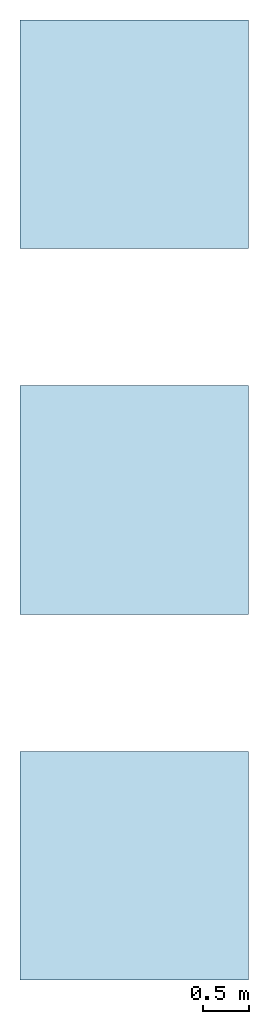
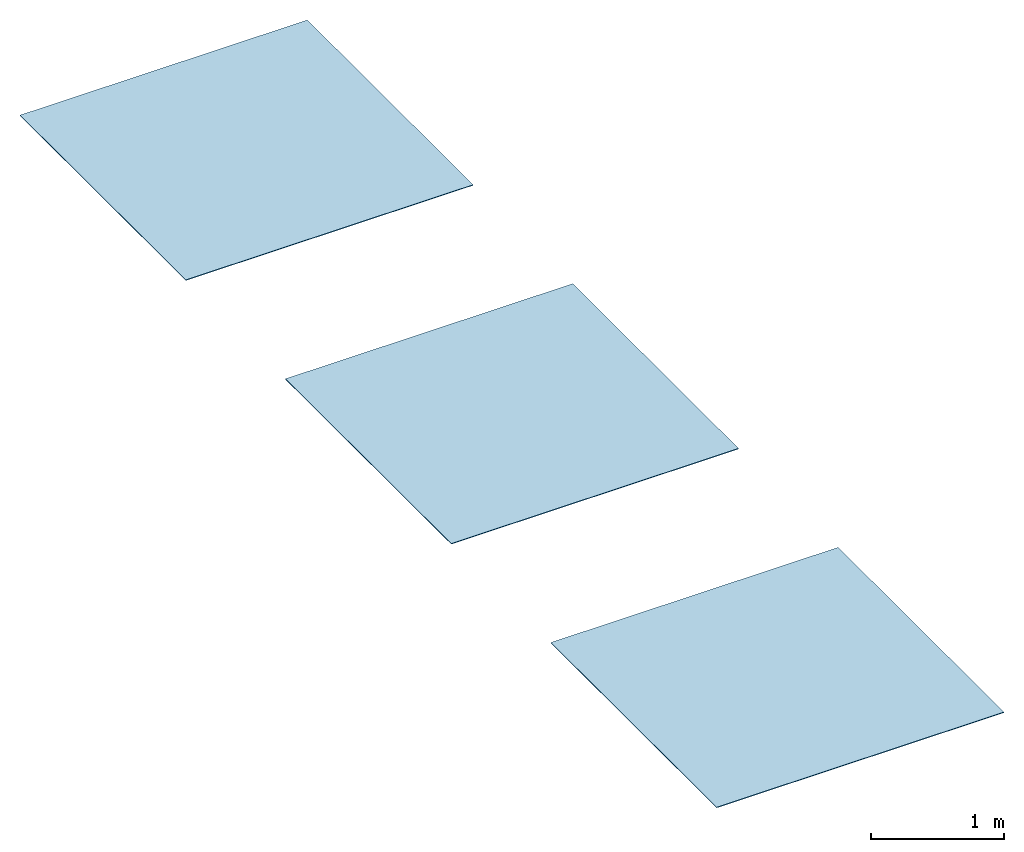
# One storey: 3 slabs, 3 elements without a shape of their own.
"""IFC2X3 building model written with IfcOpenShell, lengths in millimetres."""

from ifc_helpers import new_model, entity, si_unit, converted_unit, derived_unit, direction, frame, frame_2d, origin, place, context, subcontext, project, spatial, rectangle, extrude, material, layer, layer_set, element, aggregate, save


model = new_model("IFC2X3")

# Units and contexts
model_context = context("Model", 3, precision=0.01, world=origin(), true_north=direction((6.12303176911189e-17, 1.0)))
body_context = subcontext(model_context, "Body", "Model", "MODEL_VIEW")
ifc_project = project(units=[si_unit("LENGTHUNIT", "METRE", prefix="MILLI"), si_unit("AREAUNIT", "SQUARE_METRE"), si_unit("VOLUMEUNIT", "CUBIC_METRE"), converted_unit("PLANEANGLEUNIT", "DEGREE", entity("IfcRatioMeasure", 0.0174532925199433), si_unit("PLANEANGLEUNIT", "RADIAN"), dimensions=[0, 0, 0, 0, 0, 0, 0]), si_unit("MASSUNIT", "GRAM", prefix="KILO"), derived_unit("MASSDENSITYUNIT", [(si_unit("MASSUNIT", "GRAM", prefix="KILO"), 1), (si_unit("LENGTHUNIT", "METRE"), -3)]), si_unit("TIMEUNIT", "SECOND"), si_unit("FREQUENCYUNIT", "HERTZ"), si_unit("THERMODYNAMICTEMPERATUREUNIT", "DEGREE_CELSIUS"), derived_unit("THERMALTRANSMITTANCEUNIT", [(si_unit("MASSUNIT", "GRAM", prefix="KILO"), 1), (si_unit("THERMODYNAMICTEMPERATUREUNIT", "KELVIN"), -1), (si_unit("TIMEUNIT", "SECOND"), -3)]), derived_unit("VOLUMETRICFLOWRATEUNIT", [(si_unit("LENGTHUNIT", "METRE"), 3), (si_unit("TIMEUNIT", "SECOND"), -1)]), si_unit("ELECTRICCURRENTUNIT", "AMPERE"), si_unit("ELECTRICVOLTAGEUNIT", "VOLT"), si_unit("POWERUNIT", "WATT"), si_unit("FORCEUNIT", "NEWTON", prefix="KILO"), si_unit("ILLUMINANCEUNIT", "LUX"), si_unit("LUMINOUSFLUXUNIT", "LUMEN"), si_unit("LUMINOUSINTENSITYUNIT", "CANDELA"), derived_unit("USERDEFINED", [(si_unit("MASSUNIT", "GRAM", prefix="KILO"), -1), (si_unit("LENGTHUNIT", "METRE"), -2), (si_unit("TIMEUNIT", "SECOND"), 3), (si_unit("LUMINOUSFLUXUNIT", "LUMEN"), 1)]), derived_unit("LINEARVELOCITYUNIT", [(si_unit("LENGTHUNIT", "METRE"), 1), (si_unit("TIMEUNIT", "SECOND"), -1)]), si_unit("PRESSUREUNIT", "PASCAL"), derived_unit("USERDEFINED", [(si_unit("LENGTHUNIT", "METRE"), -2), (si_unit("MASSUNIT", "GRAM", prefix="KILO"), 1), (si_unit("TIMEUNIT", "SECOND"), -2)])], contexts=[model_context])

# Site, building, storey
site_placement = place(None, origin())
site = spatial("IfcSite", under=ifc_project, at=site_placement, CompositionType="ELEMENT")
building_placement = place(site_placement, origin())
building = spatial("IfcBuilding", under=site, at=building_placement, CompositionType="ELEMENT")
storey_placement = place(building_placement, origin())
storey = spatial("IfcBuildingStorey", under=building, at=storey_placement, Name="Level 0", CompositionType="ELEMENT", Elevation=0.0)

# Roof, slab
roof_1_placement = place(storey_placement, origin())
roof_1 = element("IfcRoof", 1, at=roof_1_placement, inside=storey, ShapeType="NOTDEFINED")
ifc_material_1 = material()
ifc_layer_1 = layer(ifc_material_1, 6.0)
ifc_layer_set_1 = layer_set([ifc_layer_1])
slab_1_placement = place(storey_placement, origin())
slab_1 = element("IfcSlab", 2, at=slab_1_placement, material=ifc_layer_set_1, PredefinedType="ROOF", context=body_context, shape_type="SweptSolid", body=[
    extrude(rectangle(XDim=2500.0, YDim=2500.0, at=frame_2d((0.0, 0.0), x_axis=(0.0, 1.0))), frame((1250.0, -1250.0, 0.0)), (0.0, 0.0, 1.0), 6.0),
])
aggregate(roof_1, [slab_1])

roof_2_placement = place(storey_placement, frame((0.0, -6500.0, 0.0)))
roof_2 = element("IfcRoof", 3, at=roof_2_placement, inside=storey, ShapeType="NOTDEFINED")
ifc_material_2 = material()
ifc_layer_2 = layer(ifc_material_2, 6.0)
ifc_layer_set_2 = layer_set([ifc_layer_2])
slab_2_placement = place(roof_2_placement, origin())
slab_2 = element("IfcSlab", 4, at=slab_2_placement, material=ifc_layer_set_2, PredefinedType="ROOF", context=body_context, shape_type="SweptSolid", body=[
    extrude(rectangle(XDim=2500.0, YDim=2500.0, at=frame_2d((0.0, -5.6843418860808e-13), x_axis=(0.0, 1.0))), frame((1250.0, 1250.0, 0.0)), (0.0, 0.0, 1.0), 6.0),
])
aggregate(roof_2, [slab_2])

roof_3_placement = place(storey_placement, frame((0.0, -10500.0, 0.0)))
roof_3 = element("IfcRoof", 5, at=roof_3_placement, inside=storey, ShapeType="NOTDEFINED")
ifc_material_3 = material()
ifc_layer_3 = layer(ifc_material_3, 6.0)
ifc_layer_set_3 = layer_set([ifc_layer_3])
slab_3_placement = place(roof_3_placement, origin())
slab_3 = element("IfcSlab", 6, at=slab_3_placement, material=ifc_layer_set_3, PredefinedType="ROOF", context=body_context, shape_type="SweptSolid", body=[
    extrude(rectangle(XDim=2500.0, YDim=2500.0, at=frame_2d((0.0, 0.0), x_axis=(0.0, 1.0))), frame((1250.0, 1250.0, 0.0)), (0.0, 0.0, 1.0), 6.0),
])
aggregate(roof_3, [slab_3])

save(model, "model.ifc")
